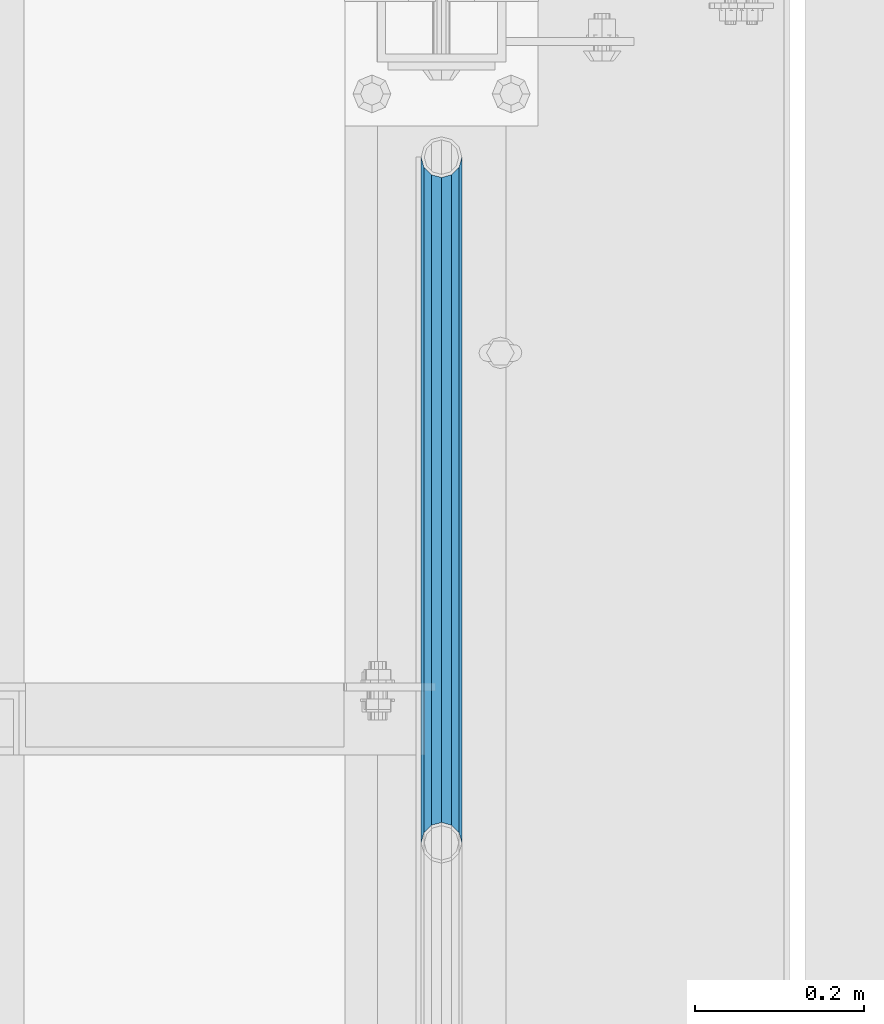
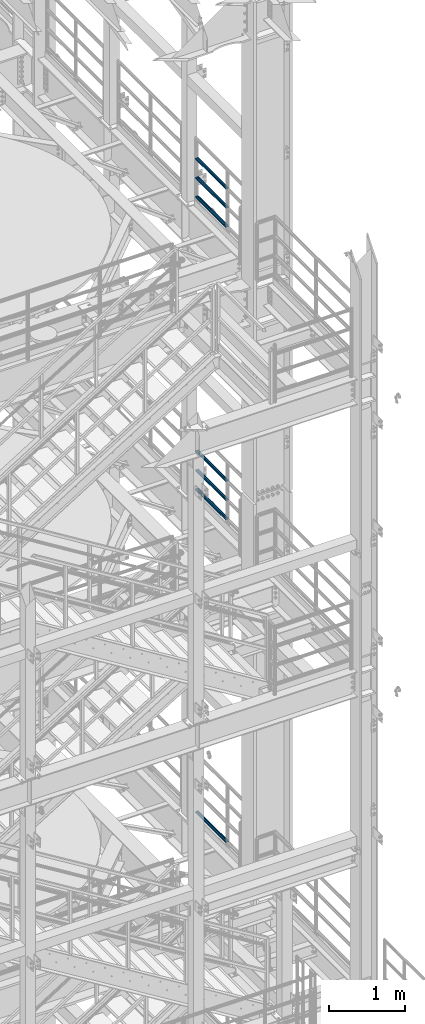
# One storey, part 1222 of 1876: 7 beams, 3 elements without a shape of their own.
"""IFC2X3 building model written with IfcOpenShell, lengths in millimetres."""

from ifc_helpers import new_model, si_unit, frame, origin_with_axes, place, context, subcontext, project, spatial, faceted_brep, material, type_object, element, aggregate, save


model = new_model("IFC2X3")

# Units and contexts
model_context = context("Model", 3, precision=1e-05, world=origin_with_axes())
body_context = subcontext(model_context, "Body", "Model", "MODEL_VIEW")
ifc_project = project(units=[si_unit("LENGTHUNIT", "METRE", prefix="MILLI"), si_unit("AREAUNIT", "SQUARE_METRE"), si_unit("VOLUMEUNIT", "CUBIC_METRE"), si_unit("MASSUNIT", "GRAM", prefix="KILO"), si_unit("TIMEUNIT", "SECOND"), si_unit("PLANEANGLEUNIT", "RADIAN"), si_unit("SOLIDANGLEUNIT", "STERADIAN"), si_unit("THERMODYNAMICTEMPERATUREUNIT", "DEGREE_CELSIUS"), si_unit("LUMINOUSINTENSITYUNIT", "LUMEN")], contexts=[model_context])

# Site, building, storey
site_placement = place(None, origin_with_axes())
site = spatial("IfcSite", under=ifc_project, at=site_placement, CompositionType="ELEMENT")
building_placement = place(site_placement, origin_with_axes())
building = spatial("IfcBuilding", under=site, at=building_placement, Name="Undefined", CompositionType="ELEMENT")
storey_placement = place(building_placement, origin_with_axes())
storey = spatial("IfcBuildingStorey", under=building, at=storey_placement, Name="Undefined", CompositionType="ELEMENT", Elevation=0.0)

# Assembly, beams
assembly_1_placement = place(storey_placement, origin_with_axes())
assembly_1 = element("IfcElementAssembly", 1, at=assembly_1_placement, inside=storey, Name="RAIL", AssemblyPlace="NOTDEFINED", PredefinedType="RIGID_FRAME")
ifc_material = material()
beam_type = type_object("IfcBeamType", Name="PIPE1-1/2SCH40", PredefinedType="NOTDEFINED")
beam_1_placement = place(assembly_1_placement, frame((7620.0, -2729.3062, 18145.125), z_axis=(0.0, 0.0, 1.0), x_axis=(0.0, -1.0, 0.0)))
beam_1 = element("IfcBeam", 2, at=beam_1_placement, type_object=beam_type, material=ifc_material, Name="RAIL", ObjectType="PIPE1-1/2SCH40", context=body_context, shape_type="Brep", body=[
    faceted_brep([(792.499707006684, -12.0649999999996, 20.8971929933177), (792.499707006684, -12.0650000000314, 15.8661214311469), (792.006278568813, -10.2235000000001, 17.7076214311819), (789.266900000001, -9.09494701772928e-13, 20.4470000000001), (789.266900000001, -9.09494701772928e-13, 24.130000000001), (792.00627856883, 10.2235000000001, 17.7076214311819), (792.499707006684, 12.0649999999678, 15.8661214312124), (792.499707006684, 12.0649999999996, 20.8971929933177), (813.396900000002, 24.1300000000001, 0.0), (801.331900000001, 20.8971929933186, 12.0649999999987), (801.331900000001, 20.8971929933186, -12.0649999999987), (798.142328437896, 17.7076214311801, 10.2235000000001), (800.881707006714, 20.4470000000001, 0.0), (798.142328437896, 17.7076214311801, -10.2235000000001), (792.499707006684, 12.0649999999678, -15.8661214312124), (792.499707006684, 12.0649999999996, -20.8971929933177), (792.00627856883, 10.2235000000001, -17.7076214311819), (789.266900000001, 0.0, -20.4470000000001), (789.266900000001, 0.0, -24.130000000001), (792.499707006684, -12.0650000000314, -15.8661214311469), (792.499707006684, -12.0649999999996, -20.8971929933177), (792.006278568813, -10.2235000000001, -17.7076214311819), (813.396900000002, -24.1300000000319, 0.0), (801.331900000001, -20.8971929933186, -12.0649999999987), (801.331900000001, -20.8971929933186, 12.0649999999987), (798.142328437831, -17.7076214311801, -10.2235000000001), (800.881707006651, -20.4470000000001, 0.0), (798.142328437831, -17.7076214311801, 10.2235000000001), (12.0650000000064, -20.8971929933177, -12.0649999999987), (20.8971929933249, -12.0650000000005, -20.8971929933177), (0.0, 24.1299999999992, 0.0), (12.0650000000064, 20.8971929933177, -12.0649999999987), (12.0650000000064, 20.8971929933177, 12.0649999999987), (20.8971929933249, 12.0650000000005, 20.8971929933177), (24.1300000000064, 0.0, 24.130000000001), (20.8971929933249, 12.0650000000005, -20.8971929933177), (24.1300000000063, 0.0, -24.130000000001), (24.1300000000063, 0.0, -20.4470000000001), (20.8971929933249, -12.0650000000005, -15.8661214311796), (21.3906214311868, -10.2235000000001, -17.7076214311819), (21.3906214311868, 10.2235000000001, -17.7076214311819), (20.8971929933249, 12.0650000000005, -15.8661214311796), (15.2545715621445, 17.7076214311801, -10.2235000000001), (12.5151929933249, 20.4470000000001, 0.0), (15.2545715621445, 17.7076214311801, 10.2235000000001), (20.8971929933249, 12.0650000000005, 15.8661214311796), (21.3906214311868, 10.2235000000001, 17.7076214311819), (24.1300000000064, 0.0, 20.4470000000001), (21.3906214311868, -10.2235000000001, 17.7076214311819), (20.8971929933249, -12.0650000000005, 15.8661214311796), (20.8971929933249, -12.0650000000005, 20.8971929933177), (12.0650000000064, -20.8971929933177, 12.0649999999987), (0.0, -24.1299999999992, 0.0), (15.2545715621445, -17.7076214311801, 10.2235000000001), (12.5151929933249, -20.4470000000001, 0.0), (15.2545715621445, -17.7076214311801, -10.2235000000001)], [[[0, 1, 2, 3, 4]], [[4, 3, 5, 6, 7]], [[8, 9, 10]], [[7, 6, 11, 12, 13, 14, 15, 10, 9]], [[16, 17, 18, 15, 14]], [[19, 20, 18, 17, 21]], [[22, 23, 24]], [[24, 23, 20, 19, 25, 26, 27, 1, 0]], [[28, 29, 20, 23]], [[30, 31, 32]], [[33, 34, 4, 7]], [[32, 33, 7, 9]], [[30, 32, 9, 8]], [[31, 30, 8, 10]], [[35, 31, 10, 15]], [[36, 35, 15, 18]], [[29, 36, 18, 20]], [[37, 36, 29, 38, 39]], [[40, 41, 35, 36, 37]], [[32, 31, 35, 41, 42, 43, 44, 45, 33]], [[33, 45, 46, 47, 34]], [[34, 47, 48, 49, 50]], [[34, 50, 0, 4]], [[50, 51, 24, 0]], [[51, 52, 22, 24]], [[52, 28, 23, 22]], [[51, 28, 52]], [[50, 49, 53, 54, 55, 38, 29, 28, 51]], [[55, 54, 26, 25]], [[21, 39, 38, 55, 25, 19]], [[37, 39, 21, 17]], [[40, 37, 17, 16]], [[42, 41, 40, 16, 14, 13]], [[43, 42, 13, 12]], [[44, 43, 12, 11]], [[5, 46, 45, 44, 11, 6]], [[47, 46, 5, 3]], [[48, 47, 3, 2]], [[53, 49, 48, 2, 1, 27]], [[54, 53, 27, 26]]]),
])
beam_2_placement = place(assembly_1_placement, frame((7620.0, -3542.7031, 18449.925), z_axis=(0.0, 0.0, -1.0), x_axis=(0.0, 1.0, 0.0)))
beam_2 = element("IfcBeam", 3, at=beam_2_placement, type_object=beam_type, material=ifc_material, Name="RAIL", ObjectType="PIPE1-1/2SCH40", context=body_context, shape_type="Brep", body=[
    faceted_brep([(0.0, 24.1299999999992, 0.0), (12.0650000000064, 20.8971929933177, -12.0649999999987), (12.0650000000064, 20.8971929933177, 12.0649999999987), (12.0650000000064, -20.8971929933177, 12.0649999999987), (12.0650000000064, -20.8971929933177, -12.0649999999987), (0.0, -24.1299999999992, 0.0), (20.8971929933249, -12.0650000000005, 20.8971929933177), (20.8971929933249, -12.0650000000005, 15.8661214311796), (15.2545715621445, -17.7076214311801, 10.2235000000001), (12.5151929933249, -20.4470000000001, 0.0), (15.2545715621445, -17.7076214311801, -10.2235000000001), (20.8971929933249, -12.0650000000005, -15.8661214311796), (20.8971929933249, -12.0650000000005, -20.8971929933177), (24.1300000000063, 0.0, -20.4470000000001), (24.1300000000063, 0.0, -24.130000000001), (21.3906214311868, -10.2235000000001, -17.7076214311819), (21.3906214311868, 10.2235000000001, -17.7076214311819), (20.8971929933249, 12.0650000000005, -15.8661214311796), (20.8971929933249, 12.0650000000005, -20.8971929933177), (15.2545715621445, 17.7076214311801, -10.2235000000001), (12.5151929933249, 20.4470000000001, 0.0), (15.2545715621445, 17.7076214311801, 10.2235000000001), (20.8971929933249, 12.0650000000005, 15.8661214311796), (20.8971929933249, 12.0650000000005, 20.8971929933177), (21.3906214311868, 10.2235000000001, 17.7076214311819), (24.1300000000064, 0.0, 20.4470000000001), (24.1300000000064, 0.0, 24.130000000001), (21.3906214311868, -10.2235000000001, 17.7076214311819), (813.396900000002, 24.1300000000001, 0.0), (801.331900000001, 20.8971929933186, -12.0649999999987), (792.499707006684, 12.0649999999996, -20.8971929933177), (813.396900000002, -24.1300000000319, 0.0), (801.331900000001, -20.8971929933186, -12.0649999999987), (801.331900000001, -20.8971929933186, 12.0649999999987), (792.499707006684, -12.0649999999996, 20.8971929933177), (792.499707006684, -12.0649999999996, -20.8971929933177), (789.266900000001, 0.0, -24.130000000001), (792.00627856883, 10.2235000000001, -17.7076214311819), (789.266900000001, 0.0, -20.4470000000001), (792.499707006684, 12.0649999999678, -15.8661214312124), (792.499707006684, -12.0650000000314, -15.8661214311469), (792.006278568813, -10.2235000000001, -17.7076214311819), (798.142328437831, -17.7076214311801, -10.2235000000001), (800.881707006651, -20.4470000000001, 0.0), (798.142328437831, -17.7076214311801, 10.2235000000001), (792.499707006684, -12.0650000000314, 15.8661214311469), (792.006278568813, -10.2235000000001, 17.7076214311819), (789.266900000001, -9.09494701772928e-13, 20.4470000000001), (789.266900000001, -9.09494701772928e-13, 24.130000000001), (792.499707006684, 12.0649999999996, 20.8971929933177), (801.331900000001, 20.8971929933186, 12.0649999999987), (792.499707006684, 12.0649999999678, 15.8661214312124), (798.142328437896, 17.7076214311801, 10.2235000000001), (800.881707006714, 20.4470000000001, 0.0), (798.142328437896, 17.7076214311801, -10.2235000000001), (792.00627856883, 10.2235000000001, 17.7076214311819)], [[[0, 1, 2]], [[3, 4, 5]], [[6, 7, 8, 9, 10, 11, 12, 4, 3]], [[13, 14, 12, 11, 15]], [[16, 17, 18, 14, 13]], [[2, 1, 18, 17, 19, 20, 21, 22, 23]], [[23, 22, 24, 25, 26]], [[26, 25, 27, 7, 6]], [[1, 0, 28, 29]], [[18, 1, 29, 30]], [[31, 32, 33]], [[6, 3, 33, 34]], [[3, 5, 31, 33]], [[5, 4, 32, 31]], [[4, 12, 35, 32]], [[12, 14, 36, 35]], [[14, 18, 30, 36]], [[37, 38, 36, 30, 39]], [[40, 35, 36, 38, 41]], [[33, 32, 35, 40, 42, 43, 44, 45, 34]], [[34, 45, 46, 47, 48]], [[26, 6, 34, 48]], [[2, 23, 49, 50]], [[23, 26, 48, 49]], [[0, 2, 50, 28]], [[28, 50, 29]], [[49, 51, 52, 53, 54, 39, 30, 29, 50]], [[48, 47, 55, 51, 49]], [[25, 24, 55, 47]], [[55, 24, 22, 21, 52, 51]], [[21, 20, 53, 52]], [[20, 19, 54, 53]], [[19, 17, 16, 37, 39, 54]], [[16, 13, 38, 37]], [[13, 15, 41, 38]], [[41, 15, 11, 10, 42, 40]], [[10, 9, 43, 42]], [[9, 8, 44, 43]], [[8, 7, 27, 46, 45, 44]], [[27, 25, 47, 46]]]),
])
beam_3_placement = place(assembly_1_placement, frame((7620.0, -3542.7031, 18754.725), z_axis=(0.0, 0.0, -1.0), x_axis=(0.0, 1.0, 0.0)))
beam_3 = element("IfcBeam", 4, at=beam_3_placement, type_object=beam_type, material=ifc_material, Name="RAIL", ObjectType="PIPE1-1/2SCH40", context=body_context, shape_type="Brep", body=[
    faceted_brep([(0.0, 24.1299999999992, 0.0), (12.0650000000064, 20.8971929933177, -12.0649999999987), (12.0650000000064, 20.8971929933177, 12.0649999999987), (12.0650000000064, -20.8971929933177, 12.0649999999987), (12.0650000000064, -20.8971929933177, -12.0649999999987), (0.0, -24.1299999999992, 0.0), (20.8971929933249, -12.0650000000005, 20.8971929933177), (20.8971929933249, -12.0650000000005, 15.8661214311796), (15.2545715621445, -17.7076214311801, 10.2235000000001), (12.5151929933249, -20.4470000000001, 0.0), (15.2545715621445, -17.7076214311801, -10.2235000000001), (20.8971929933249, -12.0650000000005, -15.8661214311796), (20.8971929933249, -12.0650000000005, -20.8971929933177), (24.1300000000063, 0.0, -20.4470000000001), (24.1300000000063, 0.0, -24.130000000001), (21.3906214311868, -10.2235000000001, -17.7076214311819), (21.3906214311868, 10.2235000000001, -17.7076214311819), (20.8971929933249, 12.0650000000005, -15.8661214311796), (20.8971929933249, 12.0650000000005, -20.8971929933177), (15.2545715621445, 17.7076214311801, -10.2235000000001), (12.5151929933249, 20.4470000000001, 0.0), (15.2545715621445, 17.7076214311801, 10.2235000000001), (20.8971929933249, 12.0650000000005, 15.8661214311796), (20.8971929933249, 12.0650000000005, 20.8971929933177), (21.3906214311868, 10.2235000000001, 17.7076214311819), (24.1300000000064, 0.0, 20.4470000000001), (24.1300000000064, 0.0, 24.130000000001), (21.3906214311868, -10.2235000000001, 17.7076214311819), (813.396900000002, 24.1300000000001, 0.0), (801.331900000001, 20.8971929933186, -12.0649999999987), (792.499707006684, 12.0649999999996, -20.8971929933177), (813.396900000002, -24.1300000000319, 0.0), (801.331900000001, -20.8971929933186, -12.0649999999987), (801.331900000001, -20.8971929933186, 12.0649999999987), (792.499707006684, -12.0649999999996, 20.8971929933177), (792.499707006684, -12.0649999999996, -20.8971929933177), (789.266900000001, 0.0, -24.130000000001), (792.00627856883, 10.2235000000001, -17.7076214311819), (789.266900000001, 0.0, -20.4470000000001), (792.499707006684, 12.0649999999678, -15.8661214312124), (792.499707006684, -12.0650000000314, -15.8661214311469), (792.006278568813, -10.2235000000001, -17.7076214311819), (798.142328437831, -17.7076214311801, -10.2235000000001), (800.881707006651, -20.4470000000001, 0.0), (798.142328437831, -17.7076214311801, 10.2235000000001), (792.499707006684, -12.0650000000314, 15.8661214311469), (792.006278568813, -10.2235000000001, 17.7076214311819), (789.266900000001, -9.09494701772928e-13, 20.4470000000001), (789.266900000001, -9.09494701772928e-13, 24.130000000001), (792.499707006684, 12.0649999999996, 20.8971929933177), (801.331900000001, 20.8971929933186, 12.0649999999987), (792.499707006684, 12.0649999999678, 15.8661214312124), (798.142328437896, 17.7076214311801, 10.2235000000001), (800.881707006714, 20.4470000000001, 0.0), (798.142328437896, 17.7076214311801, -10.2235000000001), (792.00627856883, 10.2235000000001, 17.7076214311819)], [[[0, 1, 2]], [[3, 4, 5]], [[6, 7, 8, 9, 10, 11, 12, 4, 3]], [[13, 14, 12, 11, 15]], [[16, 17, 18, 14, 13]], [[2, 1, 18, 17, 19, 20, 21, 22, 23]], [[23, 22, 24, 25, 26]], [[26, 25, 27, 7, 6]], [[1, 0, 28, 29]], [[18, 1, 29, 30]], [[31, 32, 33]], [[6, 3, 33, 34]], [[3, 5, 31, 33]], [[5, 4, 32, 31]], [[4, 12, 35, 32]], [[12, 14, 36, 35]], [[14, 18, 30, 36]], [[37, 38, 36, 30, 39]], [[40, 35, 36, 38, 41]], [[33, 32, 35, 40, 42, 43, 44, 45, 34]], [[34, 45, 46, 47, 48]], [[26, 6, 34, 48]], [[2, 23, 49, 50]], [[23, 26, 48, 49]], [[0, 2, 50, 28]], [[28, 50, 29]], [[49, 51, 52, 53, 54, 39, 30, 29, 50]], [[48, 47, 55, 51, 49]], [[25, 24, 55, 47]], [[55, 24, 22, 21, 52, 51]], [[21, 20, 53, 52]], [[20, 19, 54, 53]], [[19, 17, 16, 37, 39, 54]], [[16, 13, 38, 37]], [[13, 15, 41, 38]], [[41, 15, 11, 10, 42, 40]], [[10, 9, 43, 42]], [[9, 8, 44, 43]], [[8, 7, 27, 46, 45, 44]], [[27, 25, 47, 46]]]),
])
aggregate(assembly_1, [beam_1, beam_2, beam_3])

assembly_2_placement = place(storey_placement, origin_with_axes())
assembly_2 = element("IfcElementAssembly", 5, at=assembly_2_placement, inside=storey, Name="RAIL", AssemblyPlace="NOTDEFINED", PredefinedType="RIGID_FRAME")
beam_4_placement = place(assembly_2_placement, frame((7620.00000000003, -2729.3062, 13471.525), z_axis=(0.0, 0.0, 1.0), x_axis=(0.0, -1.0, 0.0)))
beam_4 = element("IfcBeam", 6, at=beam_4_placement, type_object=beam_type, material=ifc_material, Name="RAIL", ObjectType="PIPE1-1/2SCH40", context=body_context, shape_type="Brep", body=[
    faceted_brep([(792.499707006684, -12.0649999999996, 20.8971929933177), (792.499707006684, -12.0650000000314, 15.8661214311469), (792.006278568813, -10.2235000000001, 17.7076214311819), (789.266900000001, -9.09494701772928e-13, 20.4470000000001), (789.266900000001, -9.09494701772928e-13, 24.130000000001), (792.00627856883, 10.2235000000001, 17.7076214311819), (792.499707006684, 12.0649999999678, 15.8661214312124), (792.499707006684, 12.0649999999996, 20.8971929933177), (813.396900000002, 24.1300000000001, 0.0), (801.331900000001, 20.8971929933186, 12.0649999999987), (801.331900000001, 20.8971929933186, -12.0649999999987), (798.142328437896, 17.7076214311801, 10.2235000000001), (800.881707006714, 20.4470000000001, 0.0), (798.142328437896, 17.7076214311801, -10.2235000000001), (792.499707006684, 12.0649999999678, -15.8661214312124), (792.499707006684, 12.0649999999996, -20.8971929933177), (792.00627856883, 10.2235000000001, -17.7076214311819), (789.266900000001, 0.0, -20.4470000000001), (789.266900000001, 0.0, -24.130000000001), (792.499707006684, -12.0650000000314, -15.8661214311469), (792.499707006684, -12.0649999999996, -20.8971929933177), (792.006278568813, -10.2235000000001, -17.7076214311819), (813.396900000002, -24.1300000000319, 0.0), (801.331900000001, -20.8971929933186, -12.0649999999987), (801.331900000001, -20.8971929933186, 12.0649999999987), (798.142328437831, -17.7076214311801, -10.2235000000001), (800.881707006651, -20.4470000000001, 0.0), (798.142328437831, -17.7076214311801, 10.2235000000001), (12.0650000000064, -20.8971929933177, -12.0649999999987), (20.8971929933249, -12.0650000000005, -20.8971929933177), (0.0, 24.1299999999992, 0.0), (12.0650000000064, 20.8971929933177, -12.0649999999987), (12.0650000000064, 20.8971929933177, 12.0649999999987), (20.8971929933249, 12.0650000000005, 20.8971929933177), (24.1300000000064, 0.0, 24.130000000001), (20.8971929933249, 12.0650000000005, -20.8971929933177), (24.1300000000063, 0.0, -24.130000000001), (24.1300000000063, 0.0, -20.4470000000001), (20.8971929933249, -12.0650000000005, -15.8661214311796), (21.3906214311868, -10.2235000000001, -17.7076214311819), (21.3906214311868, 10.2235000000001, -17.7076214311819), (20.8971929933249, 12.0650000000005, -15.8661214311796), (15.2545715621445, 17.7076214311801, -10.2235000000001), (12.5151929933249, 20.4470000000001, 0.0), (15.2545715621445, 17.7076214311801, 10.2235000000001), (20.8971929933249, 12.0650000000005, 15.8661214311796), (21.3906214311868, 10.2235000000001, 17.7076214311819), (24.1300000000064, 0.0, 20.4470000000001), (21.3906214311868, -10.2235000000001, 17.7076214311819), (20.8971929933249, -12.0650000000005, 15.8661214311796), (20.8971929933249, -12.0650000000005, 20.8971929933177), (12.0650000000064, -20.8971929933177, 12.0649999999987), (0.0, -24.1299999999992, 0.0), (15.2545715621445, -17.7076214311801, 10.2235000000001), (12.5151929933249, -20.4470000000001, 0.0), (15.2545715621445, -17.7076214311801, -10.2235000000001)], [[[0, 1, 2, 3, 4]], [[4, 3, 5, 6, 7]], [[8, 9, 10]], [[7, 6, 11, 12, 13, 14, 15, 10, 9]], [[16, 17, 18, 15, 14]], [[19, 20, 18, 17, 21]], [[22, 23, 24]], [[24, 23, 20, 19, 25, 26, 27, 1, 0]], [[28, 29, 20, 23]], [[30, 31, 32]], [[33, 34, 4, 7]], [[32, 33, 7, 9]], [[30, 32, 9, 8]], [[31, 30, 8, 10]], [[35, 31, 10, 15]], [[36, 35, 15, 18]], [[29, 36, 18, 20]], [[37, 36, 29, 38, 39]], [[40, 41, 35, 36, 37]], [[32, 31, 35, 41, 42, 43, 44, 45, 33]], [[33, 45, 46, 47, 34]], [[34, 47, 48, 49, 50]], [[34, 50, 0, 4]], [[50, 51, 24, 0]], [[51, 52, 22, 24]], [[52, 28, 23, 22]], [[51, 28, 52]], [[50, 49, 53, 54, 55, 38, 29, 28, 51]], [[55, 54, 26, 25]], [[21, 39, 38, 55, 25, 19]], [[37, 39, 21, 17]], [[40, 37, 17, 16]], [[42, 41, 40, 16, 14, 13]], [[43, 42, 13, 12]], [[44, 43, 12, 11]], [[5, 46, 45, 44, 11, 6]], [[47, 46, 5, 3]], [[48, 47, 3, 2]], [[53, 49, 48, 2, 1, 27]], [[54, 53, 27, 26]]]),
])
beam_5_placement = place(assembly_2_placement, frame((7620.0, -3542.70310000001, 13776.325), z_axis=(0.0, 0.0, -1.0), x_axis=(0.0, 1.0, 0.0)))
beam_5 = element("IfcBeam", 7, at=beam_5_placement, type_object=beam_type, material=ifc_material, Name="RAIL", ObjectType="PIPE1-1/2SCH40", context=body_context, shape_type="Brep", body=[
    faceted_brep([(0.0, 24.1299999999992, 0.0), (12.0650000000064, 20.8971929933177, -12.0649999999987), (12.0650000000064, 20.8971929933177, 12.0649999999987), (12.0650000000064, -20.8971929933177, 12.0649999999987), (12.0650000000064, -20.8971929933177, -12.0649999999987), (0.0, -24.1299999999992, 0.0), (20.8971929933249, -12.0650000000005, 20.8971929933177), (20.8971929933249, -12.0650000000005, 15.8661214311796), (15.2545715621445, -17.7076214311801, 10.2235000000001), (12.5151929933249, -20.4470000000001, 0.0), (15.2545715621445, -17.7076214311801, -10.2235000000001), (20.8971929933249, -12.0650000000005, -15.8661214311796), (20.8971929933249, -12.0650000000005, -20.8971929933177), (24.1300000000063, 0.0, -20.4470000000001), (24.1300000000063, 0.0, -24.130000000001), (21.3906214311868, -10.2235000000001, -17.7076214311819), (21.3906214311868, 10.2235000000001, -17.7076214311819), (20.8971929933249, 12.0650000000005, -15.8661214311796), (20.8971929933249, 12.0650000000005, -20.8971929933177), (15.2545715621445, 17.7076214311801, -10.2235000000001), (12.5151929933249, 20.4470000000001, 0.0), (15.2545715621445, 17.7076214311801, 10.2235000000001), (20.8971929933249, 12.0650000000005, 15.8661214311796), (20.8971929933249, 12.0650000000005, 20.8971929933177), (21.3906214311868, 10.2235000000001, 17.7076214311819), (24.1300000000064, 0.0, 20.4470000000001), (24.1300000000064, 0.0, 24.130000000001), (21.3906214311868, -10.2235000000001, 17.7076214311819), (813.396900000002, 24.1300000000001, 0.0), (801.331900000001, 20.8971929933186, -12.0649999999987), (792.499707006684, 12.0649999999996, -20.8971929933177), (813.396900000002, -24.1300000000319, 0.0), (801.331900000001, -20.8971929933186, -12.0649999999987), (801.331900000001, -20.8971929933186, 12.0649999999987), (792.499707006684, -12.0649999999996, 20.8971929933177), (792.499707006684, -12.0649999999996, -20.8971929933177), (789.266900000001, 0.0, -24.130000000001), (792.00627856883, 10.2235000000001, -17.7076214311819), (789.266900000001, 0.0, -20.4470000000001), (792.499707006684, 12.0649999999678, -15.8661214312124), (792.499707006684, -12.0650000000314, -15.8661214311469), (792.006278568813, -10.2235000000001, -17.7076214311819), (798.142328437831, -17.7076214311801, -10.2235000000001), (800.881707006651, -20.4470000000001, 0.0), (798.142328437831, -17.7076214311801, 10.2235000000001), (792.499707006684, -12.0650000000314, 15.8661214311469), (792.006278568813, -10.2235000000001, 17.7076214311819), (789.266900000001, -9.09494701772928e-13, 20.4470000000001), (789.266900000001, -9.09494701772928e-13, 24.130000000001), (792.499707006684, 12.0649999999996, 20.8971929933177), (801.331900000001, 20.8971929933186, 12.0649999999987), (792.499707006684, 12.0649999999678, 15.8661214312124), (798.142328437896, 17.7076214311801, 10.2235000000001), (800.881707006714, 20.4470000000001, 0.0), (798.142328437896, 17.7076214311801, -10.2235000000001), (792.00627856883, 10.2235000000001, 17.7076214311819)], [[[0, 1, 2]], [[3, 4, 5]], [[6, 7, 8, 9, 10, 11, 12, 4, 3]], [[13, 14, 12, 11, 15]], [[16, 17, 18, 14, 13]], [[2, 1, 18, 17, 19, 20, 21, 22, 23]], [[23, 22, 24, 25, 26]], [[26, 25, 27, 7, 6]], [[1, 0, 28, 29]], [[18, 1, 29, 30]], [[31, 32, 33]], [[6, 3, 33, 34]], [[3, 5, 31, 33]], [[5, 4, 32, 31]], [[4, 12, 35, 32]], [[12, 14, 36, 35]], [[14, 18, 30, 36]], [[37, 38, 36, 30, 39]], [[40, 35, 36, 38, 41]], [[33, 32, 35, 40, 42, 43, 44, 45, 34]], [[34, 45, 46, 47, 48]], [[26, 6, 34, 48]], [[2, 23, 49, 50]], [[23, 26, 48, 49]], [[0, 2, 50, 28]], [[28, 50, 29]], [[49, 51, 52, 53, 54, 39, 30, 29, 50]], [[48, 47, 55, 51, 49]], [[25, 24, 55, 47]], [[55, 24, 22, 21, 52, 51]], [[21, 20, 53, 52]], [[20, 19, 54, 53]], [[19, 17, 16, 37, 39, 54]], [[16, 13, 38, 37]], [[13, 15, 41, 38]], [[41, 15, 11, 10, 42, 40]], [[10, 9, 43, 42]], [[9, 8, 44, 43]], [[8, 7, 27, 46, 45, 44]], [[27, 25, 47, 46]]]),
])
beam_6_placement = place(assembly_2_placement, frame((7620.0, -3542.70310000001, 14081.125), z_axis=(0.0, 0.0, -1.0), x_axis=(0.0, 1.0, 0.0)))
beam_6 = element("IfcBeam", 8, at=beam_6_placement, type_object=beam_type, material=ifc_material, Name="RAIL", ObjectType="PIPE1-1/2SCH40", context=body_context, shape_type="Brep", body=[
    faceted_brep([(0.0, 24.1299999999992, 0.0), (12.0650000000064, 20.8971929933177, -12.0649999999987), (12.0650000000064, 20.8971929933177, 12.0649999999987), (12.0650000000064, -20.8971929933177, 12.0649999999987), (12.0650000000064, -20.8971929933177, -12.0649999999987), (0.0, -24.1299999999992, 0.0), (20.8971929933249, -12.0650000000005, 20.8971929933177), (20.8971929933249, -12.0650000000005, 15.8661214311796), (15.2545715621445, -17.7076214311801, 10.2235000000001), (12.5151929933249, -20.4470000000001, 0.0), (15.2545715621445, -17.7076214311801, -10.2235000000001), (20.8971929933249, -12.0650000000005, -15.8661214311796), (20.8971929933249, -12.0650000000005, -20.8971929933177), (24.1300000000063, 0.0, -20.4470000000001), (24.1300000000063, 0.0, -24.130000000001), (21.3906214311868, -10.2235000000001, -17.7076214311819), (21.3906214311868, 10.2235000000001, -17.7076214311819), (20.8971929933249, 12.0650000000005, -15.8661214311796), (20.8971929933249, 12.0650000000005, -20.8971929933177), (15.2545715621445, 17.7076214311801, -10.2235000000001), (12.5151929933249, 20.4470000000001, 0.0), (15.2545715621445, 17.7076214311801, 10.2235000000001), (20.8971929933249, 12.0650000000005, 15.8661214311796), (20.8971929933249, 12.0650000000005, 20.8971929933177), (21.3906214311868, 10.2235000000001, 17.7076214311819), (24.1300000000064, 0.0, 20.4470000000001), (24.1300000000064, 0.0, 24.130000000001), (21.3906214311868, -10.2235000000001, 17.7076214311819), (813.396900000002, 24.1300000000001, 0.0), (801.331900000001, 20.8971929933186, -12.0649999999987), (792.499707006684, 12.0649999999996, -20.8971929933177), (813.396900000002, -24.1300000000319, 0.0), (801.331900000001, -20.8971929933186, -12.0649999999987), (801.331900000001, -20.8971929933186, 12.0649999999987), (792.499707006684, -12.0649999999996, 20.8971929933177), (792.499707006684, -12.0649999999996, -20.8971929933177), (789.266900000001, 0.0, -24.130000000001), (792.00627856883, 10.2235000000001, -17.7076214311819), (789.266900000001, 0.0, -20.4470000000001), (792.499707006684, 12.0649999999678, -15.8661214312124), (792.499707006684, -12.0650000000314, -15.8661214311469), (792.006278568813, -10.2235000000001, -17.7076214311819), (798.142328437831, -17.7076214311801, -10.2235000000001), (800.881707006651, -20.4470000000001, 0.0), (798.142328437831, -17.7076214311801, 10.2235000000001), (792.499707006684, -12.0650000000314, 15.8661214311469), (792.006278568813, -10.2235000000001, 17.7076214311819), (789.266900000001, -9.09494701772928e-13, 20.4470000000001), (789.266900000001, -9.09494701772928e-13, 24.130000000001), (792.499707006684, 12.0649999999996, 20.8971929933177), (801.331900000001, 20.8971929933186, 12.0649999999987), (792.499707006684, 12.0649999999678, 15.8661214312124), (798.142328437896, 17.7076214311801, 10.2235000000001), (800.881707006714, 20.4470000000001, 0.0), (798.142328437896, 17.7076214311801, -10.2235000000001), (792.00627856883, 10.2235000000001, 17.7076214311819)], [[[0, 1, 2]], [[3, 4, 5]], [[6, 7, 8, 9, 10, 11, 12, 4, 3]], [[13, 14, 12, 11, 15]], [[16, 17, 18, 14, 13]], [[2, 1, 18, 17, 19, 20, 21, 22, 23]], [[23, 22, 24, 25, 26]], [[26, 25, 27, 7, 6]], [[1, 0, 28, 29]], [[18, 1, 29, 30]], [[31, 32, 33]], [[6, 3, 33, 34]], [[3, 5, 31, 33]], [[5, 4, 32, 31]], [[4, 12, 35, 32]], [[12, 14, 36, 35]], [[14, 18, 30, 36]], [[37, 38, 36, 30, 39]], [[40, 35, 36, 38, 41]], [[33, 32, 35, 40, 42, 43, 44, 45, 34]], [[34, 45, 46, 47, 48]], [[26, 6, 34, 48]], [[2, 23, 49, 50]], [[23, 26, 48, 49]], [[0, 2, 50, 28]], [[28, 50, 29]], [[49, 51, 52, 53, 54, 39, 30, 29, 50]], [[48, 47, 55, 51, 49]], [[25, 24, 55, 47]], [[55, 24, 22, 21, 52, 51]], [[21, 20, 53, 52]], [[20, 19, 54, 53]], [[19, 17, 16, 37, 39, 54]], [[16, 13, 38, 37]], [[13, 15, 41, 38]], [[41, 15, 11, 10, 42, 40]], [[10, 9, 43, 42]], [[9, 8, 44, 43]], [[8, 7, 27, 46, 45, 44]], [[27, 25, 47, 46]]]),
])
aggregate(assembly_2, [beam_4, beam_5, beam_6])

# Assembly, beam
assembly_3_placement = place(storey_placement, origin_with_axes())
assembly_3 = element("IfcElementAssembly", 9, at=assembly_3_placement, inside=storey, Name="RAIL", AssemblyPlace="NOTDEFINED", PredefinedType="RIGID_FRAME")
beam_7_placement = place(assembly_3_placement, frame((7620.00000000002, -2729.3062, 8315.325), z_axis=(0.0, 0.0, 1.0), x_axis=(0.0, -1.0, 0.0)))
beam_7 = element("IfcBeam", 10, at=beam_7_placement, type_object=beam_type, material=ifc_material, Name="RAIL", ObjectType="PIPE1-1/2SCH40", context=body_context, shape_type="Brep", body=[
    faceted_brep([(792.499707006684, -12.0649999999996, 20.8971929933177), (792.499707006684, -12.0650000000314, 15.8661214311469), (792.006278568813, -10.2235000000001, 17.7076214311819), (789.266900000001, -9.09494701772928e-13, 20.4470000000001), (789.266900000001, -9.09494701772928e-13, 24.130000000001), (792.00627856883, 10.2235000000001, 17.7076214311819), (792.499707006684, 12.0649999999678, 15.8661214312124), (792.499707006684, 12.0649999999996, 20.8971929933177), (813.396900000002, 24.1300000000001, 0.0), (801.331900000001, 20.8971929933186, 12.0649999999987), (801.331900000001, 20.8971929933186, -12.0649999999987), (798.142328437896, 17.7076214311801, 10.2235000000001), (800.881707006714, 20.4470000000001, 0.0), (798.142328437896, 17.7076214311801, -10.2235000000001), (792.499707006684, 12.0649999999678, -15.8661214312124), (792.499707006684, 12.0649999999996, -20.8971929933177), (792.00627856883, 10.2235000000001, -17.7076214311819), (789.266900000001, 0.0, -20.4470000000001), (789.266900000001, 0.0, -24.130000000001), (792.499707006684, -12.0650000000314, -15.8661214311469), (792.499707006684, -12.0649999999996, -20.8971929933177), (792.006278568813, -10.2235000000001, -17.7076214311819), (813.396900000002, -24.1300000000319, 0.0), (801.331900000001, -20.8971929933186, -12.0649999999987), (801.331900000001, -20.8971929933186, 12.0649999999987), (798.142328437831, -17.7076214311801, -10.2235000000001), (800.881707006651, -20.4470000000001, 0.0), (798.142328437831, -17.7076214311801, 10.2235000000001), (12.0650000000064, -20.8971929933177, -12.0649999999987), (20.8971929933249, -12.0650000000005, -20.8971929933177), (0.0, 24.1299999999992, 0.0), (12.0650000000064, 20.8971929933177, -12.0649999999987), (12.0650000000064, 20.8971929933177, 12.0649999999987), (20.8971929933249, 12.0650000000005, 20.8971929933177), (24.1300000000064, 0.0, 24.130000000001), (20.8971929933249, 12.0650000000005, -20.8971929933177), (24.1300000000063, 0.0, -24.130000000001), (24.1300000000063, 0.0, -20.4470000000001), (20.8971929933249, -12.0650000000005, -15.8661214311796), (21.3906214311868, -10.2235000000001, -17.7076214311819), (21.3906214311868, 10.2235000000001, -17.7076214311819), (20.8971929933249, 12.0650000000005, -15.8661214311796), (15.2545715621445, 17.7076214311801, -10.2235000000001), (12.5151929933249, 20.4470000000001, 0.0), (15.2545715621445, 17.7076214311801, 10.2235000000001), (20.8971929933249, 12.0650000000005, 15.8661214311796), (21.3906214311868, 10.2235000000001, 17.7076214311819), (24.1300000000064, 0.0, 20.4470000000001), (21.3906214311868, -10.2235000000001, 17.7076214311819), (20.8971929933249, -12.0650000000005, 15.8661214311796), (20.8971929933249, -12.0650000000005, 20.8971929933177), (12.0650000000064, -20.8971929933177, 12.0649999999987), (0.0, -24.1299999999992, 0.0), (15.2545715621445, -17.7076214311801, 10.2235000000001), (12.5151929933249, -20.4470000000001, 0.0), (15.2545715621445, -17.7076214311801, -10.2235000000001)], [[[0, 1, 2, 3, 4]], [[4, 3, 5, 6, 7]], [[8, 9, 10]], [[7, 6, 11, 12, 13, 14, 15, 10, 9]], [[16, 17, 18, 15, 14]], [[19, 20, 18, 17, 21]], [[22, 23, 24]], [[24, 23, 20, 19, 25, 26, 27, 1, 0]], [[28, 29, 20, 23]], [[30, 31, 32]], [[33, 34, 4, 7]], [[32, 33, 7, 9]], [[30, 32, 9, 8]], [[31, 30, 8, 10]], [[35, 31, 10, 15]], [[36, 35, 15, 18]], [[29, 36, 18, 20]], [[37, 36, 29, 38, 39]], [[40, 41, 35, 36, 37]], [[32, 31, 35, 41, 42, 43, 44, 45, 33]], [[33, 45, 46, 47, 34]], [[34, 47, 48, 49, 50]], [[34, 50, 0, 4]], [[50, 51, 24, 0]], [[51, 52, 22, 24]], [[52, 28, 23, 22]], [[51, 28, 52]], [[50, 49, 53, 54, 55, 38, 29, 28, 51]], [[55, 54, 26, 25]], [[21, 39, 38, 55, 25, 19]], [[37, 39, 21, 17]], [[40, 37, 17, 16]], [[42, 41, 40, 16, 14, 13]], [[43, 42, 13, 12]], [[44, 43, 12, 11]], [[5, 46, 45, 44, 11, 6]], [[47, 46, 5, 3]], [[48, 47, 3, 2]], [[53, 49, 48, 2, 1, 27]], [[54, 53, 27, 26]]]),
])
aggregate(assembly_3, [beam_7])

save(model, "model.ifc")
